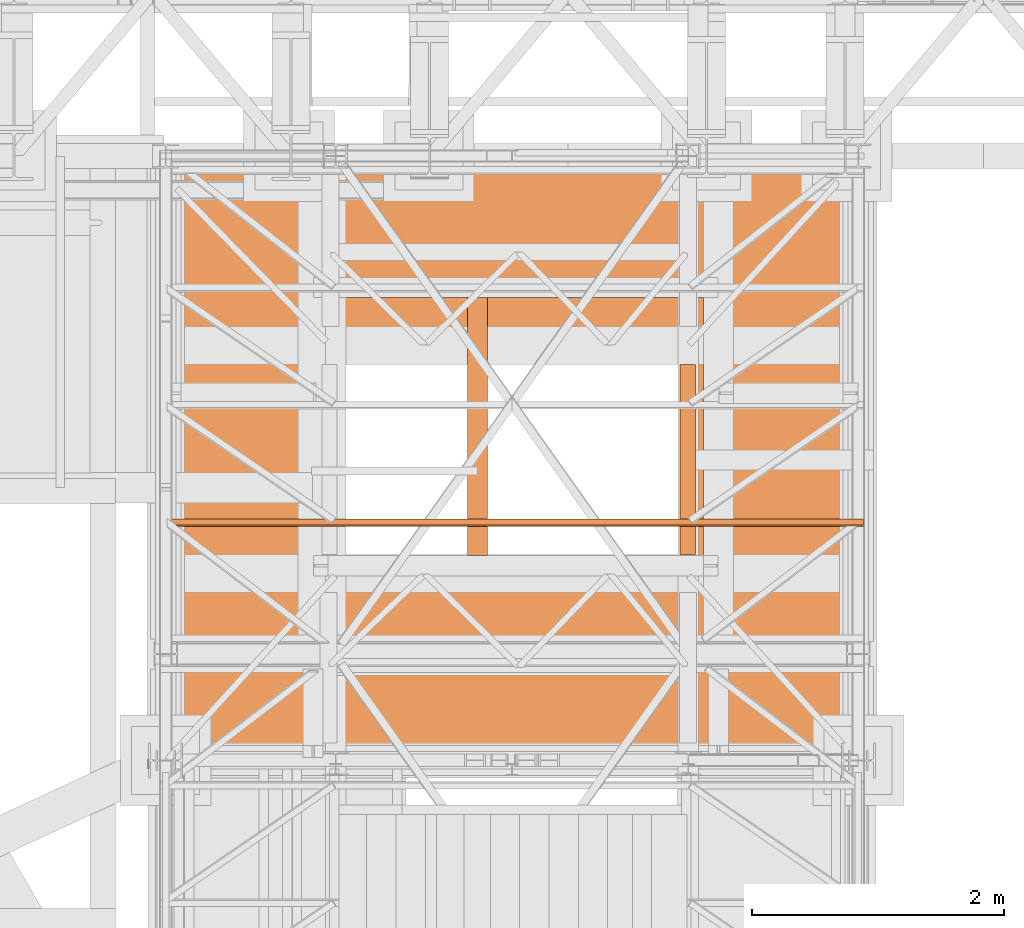
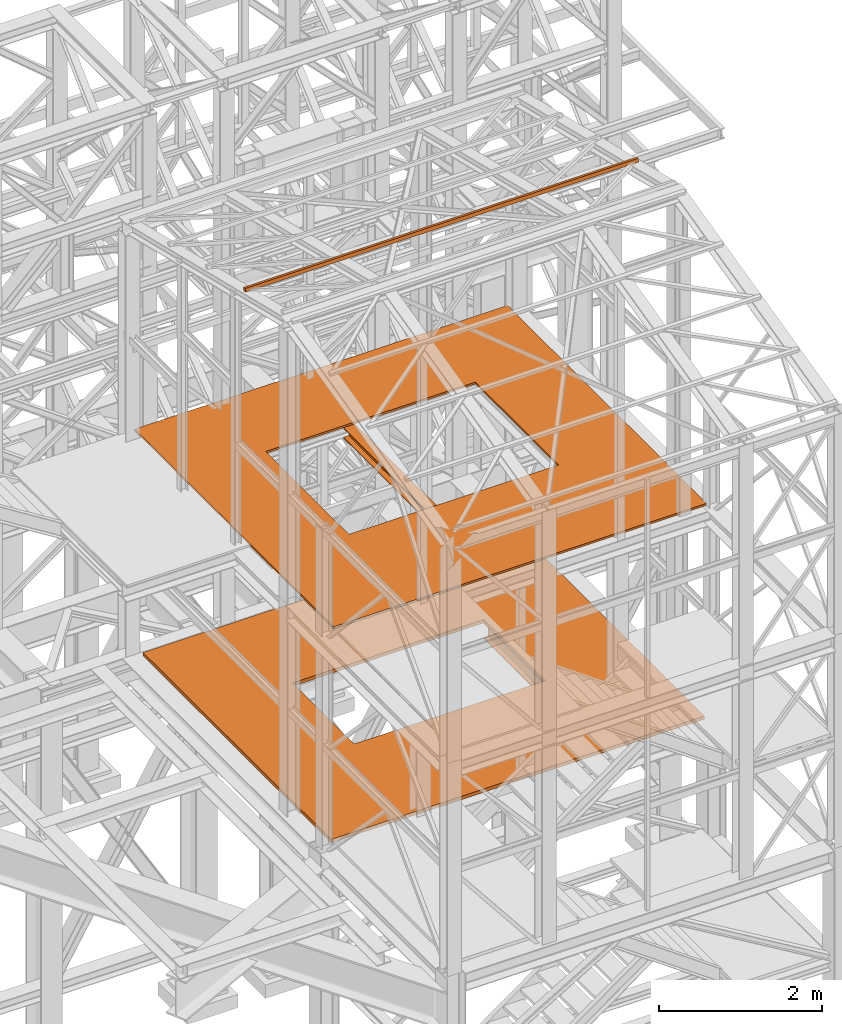
# One storey, part 64 of 208: 5 proxies.
"""IFC2X3 building model written with IfcOpenShell, lengths in millimetres."""

import ifcopenshell
import ifcopenshell.guid

model = None  # the IFC model being written
_history = None  # IfcOwnerHistory: only IFC2X3 demands one
_inside = {}  # id of a spatial element -> (the spatial element, [elements in it])
_under = {}  # id of a project, library or spatial element -> (it, [spatial elements below it])
_declared = {}  # id of a project -> (the project, [libraries it declares])
_typed = {}  # id of a type object -> (the type object, [elements of that type])
_made_of = {}  # id of a material, layer set ... -> (it, [elements and type objects made of it])


def new_model(schema):
    """Start an empty IFC model of exactly this schema.

    Asked for "IFC4X3", IfcOpenShell would pick the latest addendum, in which some entities
    have other attributes; the version numbers below select the first issue.
    IFC2X3 requires an IfcOwnerHistory on every rooted entity: one is made here for all.
    """
    global model, _history
    if schema == "IFC4X3":
        model = ifcopenshell.file(schema_version=(4, 3, 0, 0))
    else:
        model = ifcopenshell.file(schema=schema)
    _inside.clear()
    _under.clear()
    _declared.clear()
    _typed.clear()
    _made_of.clear()
    _history = None
    if model.schema == "IFC2X3":
        org = make("IfcOrganization", Name="unknown")
        user = make(
            "IfcPersonAndOrganization",
            ThePerson=make("IfcPerson", FamilyName="unknown"),
            TheOrganization=org,
        )
        app = make(
            "IfcApplication",
            ApplicationDeveloper=org,
            Version="unknown",
            ApplicationFullName="unknown",
            ApplicationIdentifier="unknown",
        )
        _history = make(
            "IfcOwnerHistory",
            OwningUser=user,
            OwningApplication=app,
            ChangeAction="ADDED",
            CreationDate=0,
        )
    return model


def make(cls, **values):
    """One entity of the class cls with the attributes given. An attribute that is None is left unset."""
    return model.create_entity(
        cls, **{name: value for name, value in values.items() if value is not None}
    )


def entity(cls, *values):
    """Any entity or typed value of the class cls, its attributes in the order of the schema. None: left unset."""
    e = model.create_entity(cls)
    for i, value in enumerate(values):
        if value is not None:
            e[i] = value
    return e


def rooted(cls, **values):
    """An entity with a GlobalId (a new one), such as an element, a storey or a relation."""
    return make(cls, GlobalId=ifcopenshell.guid.new(), OwnerHistory=_history, **values)


def si_unit(unit_type, name, prefix=None):
    """IfcSIUnit, for example si_unit("LENGTHUNIT", "METRE", prefix="MILLI")."""
    return make("IfcSIUnit", UnitType=unit_type, Prefix=prefix, Name=name)


def converted_unit(unit_type, name, factor, base, dimensions=None, offset=None):
    """IfcConversionBasedUnit, such as the inch: factor (a typed value) times the base unit."""
    return make(
        "IfcConversionBasedUnit"
        if offset is None
        else "IfcConversionBasedUnitWithOffset",
        ConversionOffset=offset,
        Dimensions=None
        if dimensions is None
        else entity("IfcDimensionalExponents", *dimensions),
        UnitType=unit_type,
        Name=name,
        ConversionFactor=make(
            "IfcMeasureWithUnit", ValueComponent=factor, UnitComponent=base
        ),
    )


def assignment(units):
    """IfcUnitAssignment: the units of a project."""
    return None if units is None else make("IfcUnitAssignment", Units=units)


def point(xyz):
    """IfcCartesianPoint."""
    return None if xyz is None else make("IfcCartesianPoint", Coordinates=xyz)


def direction(xyz):
    """IfcDirection."""
    return None if xyz is None else make("IfcDirection", DirectionRatios=xyz)


def frame(location, z_axis=None, x_axis=None):
    """IfcAxis2Placement3D, a coordinate frame: its origin and axes. An axis left out is left unset."""
    return make(
        "IfcAxis2Placement3D",
        Location=point(location),
        Axis=direction(z_axis),
        RefDirection=direction(x_axis),
    )


def origin():
    """The frame at (0, 0, 0) with its axes left unset."""
    return frame((0.0, 0.0, 0.0))


def origin_with_axes():
    """The frame at (0, 0, 0) with the z axis (0, 0, 1) and the x axis (1, 0, 0) written out."""
    return frame((0.0, 0.0, 0.0), z_axis=(0.0, 0.0, 1.0), x_axis=(1.0, 0.0, 0.0))


def place(relative_to, where):
    """IfcLocalPlacement: puts the frame where relative to a parent placement (None: the world)."""
    return make(
        "IfcLocalPlacement", PlacementRelTo=relative_to, RelativePlacement=where
    )


def context(
    kind, dimensions, precision=None, world=None, true_north=None, identifier=None
):
    """IfcGeometricRepresentationContext, for example the 3D "Model" context."""
    return make(
        "IfcGeometricRepresentationContext",
        ContextIdentifier=identifier,
        ContextType=kind,
        CoordinateSpaceDimension=dimensions,
        Precision=precision,
        WorldCoordinateSystem=world,
        TrueNorth=true_north,
    )


def subcontext(parent, identifier, kind, view, scale=None):
    """IfcGeometricRepresentationSubContext, for example "Body" below "Model"."""
    return make(
        "IfcGeometricRepresentationSubContext",
        ContextIdentifier=identifier,
        ContextType=kind,
        ParentContext=parent,
        TargetScale=scale,
        TargetView=view,
    )


def project(units=None, contexts=None):
    """IfcProject with its units and contexts."""
    return rooted(
        "IfcProject",
        Name="project",
        RepresentationContexts=contexts,
        UnitsInContext=assignment(units),
    )


def spatial(cls, under=None, at=None, **own):
    """A site, building, storey or space (cls), placed at a placement, below another one or the project."""
    s = rooted(cls, ObjectPlacement=at, **own)
    if under is not None:
        _under.setdefault(under.id(), (under, []))[1].append(s)
    return s


def faces_of(points, faces, orient=None, outer=None):
    """IfcFace entities. A face is a list of loops; a loop is a list of indices into points, from 0.

    orient and outer hold one flag for each loop. By default every Orientation is true, the
    first loop of a face is its IfcFaceOuterBound and the others are IfcFaceBound.
    """
    made = []
    for i, loops in enumerate(faces):
        bounds = []
        for j, loop in enumerate(loops):
            is_outer = j == 0 if outer is None else outer[i][j]
            bounds.append(
                make(
                    "IfcFaceOuterBound" if is_outer else "IfcFaceBound",
                    Bound=make("IfcPolyLoop", Polygon=[points[k] for k in loop]),
                    Orientation=True if orient is None else orient[i][j],
                )
            )
        made.append(make("IfcFace", Bounds=bounds))
    return made


def faceted_brep(points, faces, orient=None, outer=None, voids=None):
    """IfcFacetedBrep: a solid bounded by flat faces; with voids (closed shells), ...WithVoids."""
    shared = [point(p) for p in points]
    hull = make("IfcClosedShell", CfsFaces=faces_of(shared, faces, orient, outer))
    if voids is None:
        return make("IfcFacetedBrep", Outer=hull)
    return make(
        "IfcFacetedBrepWithVoids",
        Outer=hull,
        Voids=[
            make(cls, CfsFaces=faces_of(shared, fs, o, b)) for cls, fs, o, b in voids
        ],
    )


def shape(context_of_items, identifier, shape_type, items):
    """IfcShapeRepresentation: the items that make up one representation, for example the "Body"."""
    return make(
        "IfcShapeRepresentation",
        ContextOfItems=context_of_items,
        RepresentationIdentifier=identifier,
        RepresentationType=shape_type,
        Items=items,
    )


def made_of(thing, what):
    """Note that an element or type object is made of a material, layer set ...; save() writes the relation."""
    if what is not None:
        _made_of.setdefault(what.id(), (what, []))[1].append(thing)
    return thing


def element(
    cls,
    number,
    at=None,
    inside=None,
    cuts=None,
    type_object=None,
    material=None,
    context=None,
    identifier="Body",
    shape_type=None,
    held_by="IfcProductDefinitionShape",
    body=None,
    shapes=None,
    **own,
):
    """One element of the class cls, such as IfcWall. Its Tag is "e" and its number.

    at: its placement. inside: the storey or other place that contains it. cuts: it is an
    opening in that element (IfcRelVoidsElement). A single representation is given by context,
    identifier, shape_type and body (its items); several are given by shapes. held_by: the class
    of the entity that holds the representations. save() writes the other relations.
    """
    e = rooted(cls, Tag="e%d" % number, ObjectPlacement=at, **own)
    if body is not None:
        shapes = [shape(context, identifier, shape_type, body)]
    if shapes is not None:
        e.Representation = make(held_by, Representations=shapes)
    if inside is not None:
        _inside.setdefault(inside.id(), (inside, []))[1].append(e)
    if cuts is not None:
        rooted(
            "IfcRelVoidsElement", RelatingBuildingElement=cuts, RelatedOpeningElement=e
        )
    if type_object is not None:
        _typed.setdefault(type_object.id(), (type_object, []))[1].append(e)
    return made_of(e, material)


def aggregate(whole, parts):
    """IfcRelAggregates: a whole, such as a stair, and the parts it consists of."""
    return rooted("IfcRelAggregates", RelatingObject=whole, RelatedObjects=parts)


def save(model, path):
    """Write the relations noted so far, then the file.

    IfcRelAggregates (storeys below a building ...), IfcRelContainedInSpatialStructure (elements
    in a storey), IfcRelDefinesByType, IfcRelAssociatesMaterial and IfcRelDeclares: one each for
    every whole, place, type object, material and project.
    """
    for whole, parts in _under.values():
        aggregate(whole, parts)
    for where, things in _inside.values():
        rooted(
            "IfcRelContainedInSpatialStructure",
            RelatedElements=things,
            RelatingStructure=where,
        )
    for kind, things in _typed.values():
        rooted("IfcRelDefinesByType", RelatedObjects=things, RelatingType=kind)
    for what, things in _made_of.values():
        rooted("IfcRelAssociatesMaterial", RelatedObjects=things, RelatingMaterial=what)
    for by, libraries in _declared.values():
        rooted("IfcRelDeclares", RelatingContext=by, RelatedDefinitions=libraries)
    model.write(path)


model = new_model("IFC2X3")

# Units and contexts
model_context = context("Model", 3, precision=1e-05, world=origin())
plan_context = context("Plan", 3, precision=1e-05, world=origin())
body_context = subcontext(model_context, "Body", "Model", "MODEL_VIEW")
ifc_project = project(units=[si_unit("LENGTHUNIT", "METRE", prefix="MILLI"), converted_unit("PLANEANGLEUNIT", "DEGREE", entity("IfcPlaneAngleMeasure", 0.0174532925199433), si_unit("PLANEANGLEUNIT", "RADIAN"), dimensions=[0, 0, 0, 0, 0, 0, 0]), si_unit("AREAUNIT", "SQUARE_METRE"), si_unit("VOLUMEUNIT", "CUBIC_METRE")], contexts=[model_context, plan_context])

# Building, storey
building_placement = place(None, origin())
building = spatial("IfcBuilding", under=ifc_project, at=building_placement, CompositionType="COMPLEX")
storey_placement = place(building_placement, origin_with_axes())
storey = spatial("IfcBuildingStorey", under=building, at=storey_placement, Name="Geschoss", CompositionType="ELEMENT")

# Proxies
proxy_1_placement = place(storey_placement, frame((1298.254970018781, -22062.57439031789, 5284.990005364416), z_axis=(0.0, 0.0, 1.0), x_axis=(1.0, 0.0, 0.0)))
element("IfcBuildingElementProxy", 1, at=proxy_1_placement, inside=storey, context=body_context, shape_type="Brep", body=[
    faceted_brep([(0.01000000000021828, 0.01000000000203727, 0.01000000000021828), (5300.00999701977, 0.01000000000203727, 0.01000000000021828), (5300.009997019771, 4630.009995002234, 0.01000000000021828), (0.01000000000112777, 4630.009995002234, 0.01000000000021828), (3986.009998319893, 1634.010000189992, 0.01000000000021828), (1267.509998319894, 1634.010000189996, 0.01000000000021828), (1267.509998319895, 3144.010000189996, 0.01000000000021828), (3986.009998319894, 3144.010000189992, 0.01000000000021828), (5300.00999701977, 0.01000000000203727, 50.01000000000022), (0.01000000000021828, 0.01000000000203727, 50.01000000000022), (0.01000000000112777, 4630.009995002234, 50.01000000000022), (5300.009997019771, 4630.009995002234, 50.01000000000022), (1267.509998319894, 1634.010000189996, 50.01000000000022), (3986.009998319893, 1634.010000189992, 50.01000000000022), (3986.009998319894, 3144.010000189996, 50.01000000000022), (1267.509998319895, 3144.010000189996, 50.01000000000022), (5300.00999701977, 0.01000000000203727, 0.01000000000021828), (0.01000000000021828, 0.01000000000203727, 0.01000000000021828), (0.01000000000021828, 0.01000000000203727, 50.01000000000022), (5300.00999701977, 0.01000000000203727, 50.01000000000022), (5300.009997019771, 4630.009995002234, 0.01000000000021828), (5300.00999701977, 0.01000000000203727, 0.01000000000021828), (5300.00999701977, 0.01000000000203727, 50.01000000000022), (5300.009997019771, 4630.009995002234, 50.01000000000022), (0.01000000000112777, 4630.009995002234, 0.01000000000021828), (5300.009997019771, 4630.009995002234, 0.01000000000021828), (5300.009997019771, 4630.009995002234, 50.01000000000022), (0.01000000000112777, 4630.009995002234, 50.01000000000022), (0.01000000000021828, 0.01000000000203727, 0.01000000000021828), (0.01000000000112777, 4630.009995002234, 0.01000000000021828), (0.01000000000112777, 4630.009995002234, 50.01000000000022), (0.01000000000021828, 0.01000000000203727, 50.01000000000022), (1267.509998319894, 1634.010000189996, 0.01000000000021828), (3986.009998319893, 1634.010000189992, 0.01000000000021828), (3986.009998319893, 1634.010000189992, 50.01000000000022), (1267.509998319894, 1634.010000189996, 50.01000000000022), (3986.009998319893, 1634.010000189992, 0.01000000000021828), (3986.009998319894, 3144.010000189992, 0.01000000000021828), (3986.009998319894, 3144.010000189996, 50.01000000000022), (3986.009998319893, 1634.010000189992, 50.01000000000022), (3986.009998319894, 3144.010000189992, 0.01000000000021828), (1267.509998319895, 3144.010000189996, 0.01000000000021828), (1267.509998319895, 3144.010000189996, 50.01000000000022), (3986.009998319894, 3144.010000189996, 50.01000000000022), (1267.509998319895, 3144.010000189996, 0.01000000000021828), (1267.509998319894, 1634.010000189996, 0.01000000000021828), (1267.509998319894, 1634.010000189996, 50.01000000000022), (1267.509998319895, 3144.010000189996, 50.01000000000022)], [[[0, 1, 2, 3], [4, 5, 6, 7]], [[8, 9, 10, 11], [12, 13, 14, 15]], [[16, 17, 18, 19]], [[20, 21, 22, 23]], [[24, 25, 26, 27]], [[28, 29, 30, 31]], [[32, 33, 34, 35]], [[36, 37, 38, 39]], [[40, 41, 42, 43]], [[44, 45, 46, 47]]], orient=[[False, False], [False, False], [False], [False], [False], [False], [False], [False], [False], [False]]),
])
proxy_2_placement = place(storey_placement, frame((3592.968166618113, -20436.85029743702, 8332.990002086155), z_axis=(0.0, 0.0, 1.0), x_axis=(1.0, 0.0, 0.0)))
element("IfcBuildingElementProxy", 2, at=proxy_2_placement, inside=storey, context=body_context, shape_type="Brep", body=[
    faceted_brep([(160.0100000000002, 2050.009999999998, 0.01000000000021828), (160.0100000000002, 0.00999999999839929, 0.01000000000021828), (160.0100000000002, 0.00999999999839929, 9.010000000000218), (160.0100000000002, 2050.009999999998, 9.010000000000218), (160.0100000000002, 2050.009999999998, 9.010000000000218), (160.0100000000002, 0.00999999999839929, 9.010000000000218), (83.01000000000022, 0.00999999999839929, 9.010000000000218), (83.01000000000022, 2050.009999999998, 9.010000000000218), (83.01000000000022, 2050.009999999998, 9.010000000000218), (83.01000000000022, 0.00999999999839929, 9.010000000000218), (83.01000000000022, 0.00999999999839929, 143.0100000000002), (83.01000000000022, 2050.009999999998, 143.0100000000002), (83.01000000000022, 2050.009999999998, 143.0100000000002), (83.01000000000022, 0.00999999999839929, 143.0100000000002), (160.0100000000002, 0.00999999999839929, 143.0100000000002), (160.0100000000002, 2050.009999999998, 143.0100000000002), (160.0100000000002, 2050.009999999998, 143.0100000000002), (160.0100000000002, 0.00999999999839929, 143.0100000000002), (160.0100000000002, 0.00999999999839929, 152.0100000000002), (160.0100000000002, 2050.009999999998, 152.0100000000002), (160.0100000000002, 2050.009999999998, 152.0100000000002), (160.0100000000002, 0.00999999999839929, 152.0100000000002), (0.01000000000021828, 0.00999999999839929, 152.0100000000002), (0.01000000000021828, 2050.009999999998, 152.0100000000002), (0.01000000000021828, 2050.009999999998, 152.0100000000002), (0.01000000000021828, 0.00999999999839929, 152.0100000000002), (0.01000000000021828, 0.00999999999839929, 143.0100000000002), (0.01000000000021828, 2050.009999999998, 143.0100000000002), (0.01000000000021828, 2050.009999999998, 143.0100000000002), (0.01000000000021828, 0.00999999999839929, 143.0100000000002), (77.01000000000022, 0.00999999999839929, 143.0100000000002), (77.01000000000022, 2050.009999999998, 143.0100000000002), (77.01000000000022, 2050.009999999998, 143.0100000000002), (77.01000000000022, 0.00999999999839929, 143.0100000000002), (77.01000000000022, 0.00999999999839929, 9.010000000000218), (77.01000000000022, 2050.009999999998, 9.010000000000218), (77.01000000000022, 2050.009999999998, 9.010000000000218), (77.01000000000022, 0.00999999999839929, 9.010000000000218), (0.01000000000021828, 0.00999999999839929, 9.010000000000218), (0.01000000000021828, 2050.009999999998, 9.010000000000218), (0.01000000000021828, 2050.009999999998, 9.010000000000218), (0.01000000000021828, 0.00999999999839929, 9.010000000000218), (0.01000000000021828, 0.00999999999839929, 0.01000000000021828), (0.01000000000021828, 2050.009999999998, 0.01000000000021828), (0.01000000000021828, 2050.009999999998, 0.01000000000021828), (0.01000000000021828, 0.00999999999839929, 0.01000000000021828), (160.0100000000002, 0.00999999999839929, 0.01000000000021828), (160.0100000000002, 2050.009999999998, 0.01000000000021828), (160.0100000000002, 2050.009999999998, 0.01000000000021828), (160.0100000000002, 2050.009999999998, 9.010000000000218), (83.01000000000022, 2050.009999999998, 9.010000000000218), (83.01000000000022, 2050.009999999998, 143.0100000000002), (160.0100000000002, 2050.009999999998, 143.0100000000002), (160.0100000000002, 2050.009999999998, 152.0100000000002), (0.01000000000021828, 2050.009999999998, 152.0100000000002), (0.01000000000021828, 2050.009999999998, 143.0100000000002), (77.01000000000022, 2050.009999999998, 143.0100000000002), (77.01000000000022, 2050.009999999998, 9.010000000000218), (0.01000000000021828, 2050.009999999998, 9.010000000000218), (0.01000000000021828, 2050.009999999998, 0.01000000000021828), (160.0100000000002, 0.00999999999839929, 0.01000000000021828), (0.01000000000021828, 0.00999999999839929, 0.01000000000021828), (0.01000000000021828, 0.00999999999839929, 9.010000000000218), (77.01000000000022, 0.00999999999839929, 9.010000000000218), (77.01000000000022, 0.00999999999839929, 143.0100000000002), (0.01000000000021828, 0.00999999999839929, 143.0100000000002), (0.01000000000021828, 0.00999999999839929, 152.0100000000002), (160.0100000000002, 0.00999999999839929, 152.0100000000002), (160.0100000000002, 0.00999999999839929, 143.0100000000002), (83.01000000000022, 0.00999999999839929, 143.0100000000002), (83.01000000000022, 0.00999999999839929, 9.010000000000218), (160.0100000000002, 0.00999999999839929, 9.010000000000218)], [[[0, 1, 2, 3]], [[4, 5, 6, 7]], [[8, 9, 10, 11]], [[12, 13, 14, 15]], [[16, 17, 18, 19]], [[20, 21, 22, 23]], [[24, 25, 26, 27]], [[28, 29, 30, 31]], [[32, 33, 34, 35]], [[36, 37, 38, 39]], [[40, 41, 42, 43]], [[44, 45, 46, 47]], [[48, 49, 50, 51, 52, 53, 54, 55, 56, 57, 58, 59]], [[60, 61, 62, 63, 64, 65, 66, 67, 68, 69, 70, 71]]], orient=[[False], [False], [False], [False], [False], [False], [False], [False], [False], [False], [False], [False], [False], [False]]),
])
proxy_3_placement = place(storey_placement, frame((1333.25497001878, -22062.57439031789, 8484.990002086157), z_axis=(0.0, 0.0, 1.0), x_axis=(1.0, 0.0, 0.0)))
element("IfcBuildingElementProxy", 3, at=proxy_3_placement, inside=storey, context=body_context, shape_type="Brep", body=[
    faceted_brep([(0.01000000000021828, 0.00999999999839929, 0.01000000000021828), (5300.009997019771, 0.00999999999839929, 0.01000000000021828), (5300.009997019771, 4900.010004949752, 0.01000000000021828), (0.01000000000112777, 4900.010004949756, 0.01000000000021828), (4135.009993741514, 1625.734092880863, 0.01000000000021828), (1155.010003278258, 1625.734092880866, 0.01000000000021828), (1155.010003278258, 3675.734081555984, 0.01000000000021828), (4135.009993741515, 3675.734081555984, 0.01000000000021828), (5300.009997019771, 0.00999999999839929, 30.01000000000022), (0.01000000000021828, 0.00999999999839929, 30.01000000000022), (0.01000000000112777, 4900.010004949756, 30.01000000000022), (5300.009997019771, 4900.010004949752, 30.01000000000022), (1155.010003278258, 1625.734092880866, 30.01000000000022), (4135.009993741513, 1625.734092880863, 30.01000000000022), (4135.009993741514, 3675.734081555984, 30.01000000000022), (1155.010003278258, 3675.734081555984, 30.01000000000022), (5300.009997019771, 0.00999999999839929, 0.01000000000021828), (0.01000000000021828, 0.00999999999839929, 0.01000000000021828), (0.01000000000021828, 0.00999999999839929, 30.01000000000022), (5300.009997019771, 0.00999999999839929, 30.01000000000022), (5300.009997019771, 4900.010004949752, 0.01000000000021828), (5300.009997019771, 0.00999999999839929, 0.01000000000021828), (5300.009997019771, 0.00999999999839929, 30.01000000000022), (5300.009997019771, 4900.010004949752, 30.01000000000022), (0.01000000000112777, 4900.010004949756, 0.01000000000021828), (5300.009997019771, 4900.010004949752, 0.01000000000021828), (5300.009997019771, 4900.010004949752, 30.01000000000022), (0.01000000000112777, 4900.010004949756, 30.01000000000022), (0.01000000000021828, 0.00999999999839929, 0.01000000000021828), (0.01000000000112777, 4900.010004949756, 0.01000000000021828), (0.01000000000112777, 4900.010004949756, 30.01000000000022), (0.01000000000021828, 0.00999999999839929, 30.01000000000022), (1155.010003278258, 1625.734092880866, 0.01000000000021828), (4135.009993741514, 1625.734092880863, 0.01000000000021828), (4135.009993741513, 1625.734092880863, 30.01000000000022), (1155.010003278258, 1625.734092880866, 30.01000000000022), (4135.009993741514, 1625.734092880863, 0.01000000000021828), (4135.009993741515, 3675.734081555984, 0.01000000000021828), (4135.009993741514, 3675.734081555984, 30.01000000000022), (4135.009993741513, 1625.734092880863, 30.01000000000022), (4135.009993741515, 3675.734081555984, 0.01000000000021828), (1155.010003278258, 3675.734081555984, 0.01000000000021828), (1155.010003278258, 3675.734081555984, 30.01000000000022), (4135.009993741514, 3675.734081555984, 30.01000000000022), (1155.010003278258, 3675.734081555984, 0.01000000000021828), (1155.010003278258, 1625.734092880866, 0.01000000000021828), (1155.010003278258, 1625.734092880866, 30.01000000000022), (1155.010003278258, 3675.734081555984, 30.01000000000022)], [[[0, 1, 2, 3], [4, 5, 6, 7]], [[8, 9, 10, 11], [12, 13, 14, 15]], [[16, 17, 18, 19]], [[20, 21, 22, 23]], [[24, 25, 26, 27]], [[28, 29, 30, 31]], [[32, 33, 34, 35]], [[36, 37, 38, 39]], [[40, 41, 42, 43]], [[44, 45, 46, 47]]], orient=[[False, False], [False, False], [False], [False], [False], [False], [False], [False], [False], [False]]),
])
proxy_4_placement = place(storey_placement, frame((1157.254971121463, -20206.02192199566, 12464.98408158565), z_axis=(0.0, 0.0, 1.0), x_axis=(1.0, 0.0, 0.0)))
element("IfcBuildingElementProxy", 4, at=proxy_4_placement, inside=storey, context=body_context, shape_type="Brep", body=[
    faceted_brep([(5582.010002264973, 11.80406569683692, 60.39315927079588), (5582.010002264973, 60.39315927079224, 48.59909357395736), (5582.010002264973, 48.59909357395372, 0.01000000000021828), (5582.010002264973, 0.00999999999839929, 11.80406569683873), (0.01000000000021828, 60.39315927079224, 48.59909357395736), (0.01000000000021828, 11.80406569683692, 60.39315927079588), (0.01000000000021828, 0.00999999999839929, 11.80406569683873), (0.01000000000021828, 48.59909357395372, 0.01000000000021828), (5582.010002264973, 60.39315927079224, 48.59909357395736), (5582.010002264973, 11.80406569683692, 60.39315927079588), (0.01000000000021828, 11.80406569683692, 60.39315927079588), (0.01000000000021828, 60.39315927079224, 48.59909357395736), (5582.010002264973, 48.59909357395372, 0.01000000000021828), (5582.010002264973, 60.39315927079224, 48.59909357395736), (0.01000000000021828, 60.39315927079224, 48.59909357395736), (0.01000000000021828, 48.59909357395372, 0.01000000000021828), (5582.010002264973, 0.00999999999839929, 11.80406569683873), (5582.010002264973, 48.59909357395372, 0.01000000000021828), (0.01000000000021828, 48.59909357395372, 0.01000000000021828), (0.01000000000021828, 0.00999999999839929, 11.80406569683873), (5582.010002264973, 11.80406569683692, 60.39315927079588), (5582.010002264973, 0.00999999999839929, 11.80406569683873), (0.01000000000021828, 0.00999999999839929, 11.80406569683873), (0.01000000000021828, 11.80406569683692, 60.39315927079588)], [[[0, 1, 2, 3]], [[4, 5, 6, 7]], [[8, 9, 10, 11]], [[12, 13, 14, 15]], [[16, 17, 18, 19]], [[20, 21, 22, 23]]], orient=[[False], [False], [False], [False], [False], [False]]),
])
proxy_5_placement = place(storey_placement, frame((5284.254968338673, -20428.5743901279, 5044.990005364415), z_axis=(0.0, 0.0, 1.0), x_axis=(1.0, 0.0, 0.0)))
element("IfcBuildingElementProxy", 5, at=proxy_5_placement, inside=storey, context=body_context, shape_type="Brep", body=[
    faceted_brep([(120.0100000000002, 1510.010000000006, 0.01000000000021828), (120.0100000000002, 0.01000000000567525, 0.01000000000021828), (120.0100000000002, 0.01000000000567525, 9.810000190735082), (120.0100000000002, 1510.010000000006, 9.810000190735082), (120.0100000000002, 1510.010000000006, 9.810000190735082), (120.0100000000002, 0.01000000000567525, 9.810000190735082), (78.10999990463279, 0.01000000000203727, 9.810000190735082), (78.10999990463279, 1510.010000000006, 9.810000190735082), (78.10999990463279, 1510.010000000006, 9.810000190735082), (78.10999990463279, 0.01000000000203727, 9.810000190735082), (74.22772724864444, 0.01000000000567525, 10.32115675323166), (74.22772724864444, 1510.010000000006, 10.32115675323075), (74.22772724864444, 1510.010000000006, 10.32115675323075), (74.22772724864444, 0.01000000000567525, 10.32115675323166), (70.61002177988667, 0.01000000000567525, 11.81965942306215), (70.61002177988667, 1510.010000000006, 11.81965942306215), (70.61002177988667, 1510.010000000006, 11.81965942306215), (70.61002177988667, 0.01000000000567525, 11.81965942306215), (67.5033981868346, 0.01000000000567525, 14.2033984729369), (67.5033981868346, 1510.010000000006, 14.2033984729369), (67.5033981868346, 1510.010000000006, 14.2033984729369), (67.5033981868346, 0.01000000000567525, 14.2033984729369), (65.11965913696076, 0.01000000000567525, 17.31002206598896), (65.11965913696076, 1510.010000000006, 17.31002206598896), (65.11965913696076, 1510.010000000006, 17.31002206598896), (65.11965913696076, 0.01000000000567525, 17.31002206598896), (63.62115646713028, 0.01000000000567525, 20.92772753474765), (63.62115646713028, 1510.010000000006, 20.92772753474765), (63.62115646713028, 1510.010000000006, 20.92772753474765), (63.62115646713028, 0.01000000000567525, 20.92772753474765), (63.10999990463279, 0.01000000000203727, 24.81000019073508), (63.10999990463279, 1510.010000000006, 24.81000019073508), (63.10999990463279, 1510.010000000006, 24.81000019073508), (63.10999990463279, 0.01000000000203727, 24.81000019073508), (63.10999990463279, 0.01000000000567525, 215.2099998092654), (63.10999990463279, 1510.010000000006, 215.2099998092654), (63.10999990463279, 1510.010000000006, 215.2099998092654), (63.10999990463279, 0.01000000000567525, 215.2099998092654), (63.62115646713028, 0.01000000000567525, 219.0922724652519), (63.62115646713028, 1510.010000000006, 219.0922724652519), (63.62115646713028, 1510.010000000006, 219.0922724652519), (63.62115646713028, 0.01000000000567525, 219.0922724652519), (65.11965913696076, 0.01000000000567525, 222.7099779340106), (65.11965913696076, 1510.010000000006, 222.7099779340106), (65.11965913696076, 1510.010000000006, 222.7099779340106), (65.11965913696076, 0.01000000000567525, 222.7099779340106), (67.5033981868346, 0.01000000000567525, 225.8166015270635), (67.5033981868346, 1510.010000000006, 225.8166015270635), (67.5033981868346, 1510.010000000006, 225.8166015270635), (67.5033981868346, 0.01000000000567525, 225.8166015270635), (70.61002177988667, 0.01000000000203727, 228.2003405769374), (70.61002177988667, 1510.010000000006, 228.2003405769374), (70.61002177988667, 1510.010000000006, 228.2003405769374), (70.61002177988667, 0.01000000000203727, 228.2003405769374), (74.22772724864444, 0.01000000000567525, 229.6988432467679), (74.22772724864444, 1510.010000000006, 229.6988432467679), (74.22772724864444, 1510.010000000006, 229.6988432467679), (74.22772724864444, 0.01000000000567525, 229.6988432467679), (78.10999990463279, 0.01000000000567525, 230.2099998092654), (78.10999990463279, 1510.010000000006, 230.2099998092654), (78.10999990463279, 1510.010000000006, 230.2099998092654), (78.10999990463279, 0.01000000000567525, 230.2099998092654), (120.0100000000002, 0.01000000000567525, 230.2099998092654), (120.0100000000002, 1510.010000000006, 230.2099998092654), (120.0100000000002, 1510.010000000006, 230.2099998092654), (120.0100000000002, 0.01000000000567525, 230.2099998092654), (120.0100000000002, 0.01000000000567525, 240.0100000000002), (120.0100000000002, 1510.010000000006, 240.0100000000002), (120.0100000000002, 1510.010000000006, 240.0100000000002), (120.0100000000002, 0.01000000000567525, 240.0100000000002), (0.01000000000021828, 0.01000000000567525, 240.0100000000002), (0.01000000000021828, 1510.010000000006, 240.0100000000002), (0.01000000000021828, 1510.010000000006, 240.0100000000002), (0.01000000000021828, 0.01000000000567525, 240.0100000000002), (0.01000000000021828, 0.01000000000567525, 230.2099998092654), (0.01000000000021828, 1510.010000000006, 230.2099998092654), (0.01000000000021828, 1510.010000000006, 230.2099998092654), (0.01000000000021828, 0.01000000000567525, 230.2099998092654), (41.91000009536765, 0.01000000000567525, 230.2099998092654), (41.91000009536765, 1510.010000000006, 230.2099998092654), (41.91000009536765, 1510.010000000006, 230.2099998092654), (41.91000009536765, 0.01000000000567525, 230.2099998092654), (45.792272751356, 0.01000000000567525, 229.6988432467679), (45.792272751356, 1510.010000000006, 229.6988432467679), (45.792272751356, 1510.010000000006, 229.6988432467679), (45.792272751356, 0.01000000000567525, 229.6988432467679), (49.40997822011377, 0.01000000000567525, 228.2003405769374), (49.40997822011377, 1510.010000000006, 228.2003405769374), (49.40997822011377, 1510.010000000006, 228.2003405769374), (49.40997822011377, 0.01000000000567525, 228.2003405769374), (52.51660181316584, 0.01000000000567525, 225.8166015270645), (52.51660181316584, 1510.010000000006, 225.8166015270635), (52.51660181316584, 1510.010000000006, 225.8166015270635), (52.51660181316584, 0.01000000000567525, 225.8166015270645), (54.90034086303967, 0.01000000000567525, 222.7099779340106), (54.90034086303967, 1510.010000000006, 222.7099779340106), (54.90034086303967, 1510.010000000006, 222.7099779340106), (54.90034086303967, 0.01000000000567525, 222.7099779340106), (56.39884353287016, 0.01000000000567525, 219.0922724652519), (56.39884353287016, 1510.010000000006, 219.0922724652519), (56.39884353287016, 1510.010000000006, 219.0922724652519), (56.39884353287016, 0.01000000000567525, 219.0922724652519), (56.91000009536765, 0.01000000000567525, 215.2099998092654), (56.91000009536765, 1510.010000000006, 215.2099998092654), (56.91000009536765, 1510.010000000006, 215.2099998092654), (56.91000009536765, 0.01000000000567525, 215.2099998092654), (56.91000009536765, 0.01000000000567525, 24.81000019073508), (56.91000009536765, 1510.010000000006, 24.81000019073508), (56.91000009536765, 1510.010000000006, 24.81000019073508), (56.91000009536765, 0.01000000000567525, 24.81000019073508), (56.17579672995453, 0.01000000000567525, 20.17476099858959), (56.17579672995453, 1510.010000000006, 20.17476099858959), (56.17579672995453, 1510.010000000006, 20.17476099858959), (56.17579672995453, 0.01000000000567525, 20.17476099858959), (54.0452364639259, 0.01000000000567525, 15.99323626528985), (54.0452364639259, 1510.010000000006, 15.99323626528985), (54.0452364639259, 1510.010000000006, 15.99323626528985), (54.0452364639259, 0.01000000000567525, 15.99323626528985), (50.72676402081379, 0.01000000000567525, 12.67476382217774), (50.72676402081379, 1510.010000000006, 12.67476382217774), (50.72676402081379, 1510.010000000006, 12.67476382217774), (50.72676402081379, 0.01000000000567525, 12.67476382217774), (46.54523928751405, 0.01000000000567525, 10.5442035561473), (46.54523928751405, 1510.010000000006, 10.54420355614639), (46.54523928751405, 1510.010000000006, 10.54420355614639), (46.54523928751405, 0.01000000000567525, 10.5442035561473), (41.91000009536765, 0.01000000000567525, 9.810000190735082), (41.91000009536765, 1510.010000000006, 9.810000190735082), (41.91000009536765, 1510.010000000006, 9.810000190735082), (41.91000009536765, 0.01000000000567525, 9.810000190735082), (0.01000000000021828, 0.01000000000203727, 9.810000190735082), (0.01000000000021828, 1510.010000000006, 9.810000190735082), (0.01000000000021828, 1510.010000000006, 9.810000190735082), (0.01000000000021828, 0.01000000000203727, 9.810000190735082), (0.01000000000021828, 0.01000000000567525, 0.01000000000021828), (0.01000000000021828, 1510.010000000006, 0.01000000000021828), (0.01000000000021828, 1510.010000000006, 0.01000000000021828), (0.01000000000021828, 0.01000000000567525, 0.01000000000021828), (120.0100000000002, 0.01000000000567525, 0.01000000000021828), (120.0100000000002, 1510.010000000006, 0.01000000000021828), (120.0100000000002, 0.01000000000567525, 0.01000000000021828), (0.01000000000021828, 0.01000000000567525, 0.01000000000021828), (0.01000000000021828, 0.01000000000203727, 9.810000190735082), (41.91000009536765, 0.01000000000567525, 9.810000190735082), (46.54523928751405, 0.01000000000567525, 10.5442035561473), (50.72676402081379, 0.01000000000567525, 12.67476382217774), (54.0452364639259, 0.01000000000567525, 15.99323626528985), (56.17579672995453, 0.01000000000567525, 20.17476099858959), (56.91000009536765, 0.01000000000567525, 24.81000019073508), (56.91000009536765, 0.01000000000567525, 215.2099998092654), (56.39884353287016, 0.01000000000567525, 219.0922724652519), (54.90034086303967, 0.01000000000567525, 222.7099779340106), (52.51660181316584, 0.01000000000567525, 225.8166015270645), (49.40997822011377, 0.01000000000567525, 228.2003405769374), (45.792272751356, 0.01000000000567525, 229.6988432467679), (41.91000009536765, 0.01000000000567525, 230.2099998092654), (0.01000000000021828, 0.01000000000567525, 230.2099998092654), (0.01000000000021828, 0.01000000000567525, 240.0100000000002), (120.0100000000002, 0.01000000000567525, 240.0100000000002), (120.0100000000002, 0.01000000000567525, 230.2099998092654), (78.10999990463279, 0.01000000000567525, 230.2099998092654), (74.22772724864444, 0.01000000000567525, 229.6988432467679), (70.61002177988667, 0.01000000000203727, 228.2003405769374), (67.5033981868346, 0.01000000000567525, 225.8166015270635), (65.11965913696076, 0.01000000000567525, 222.7099779340106), (63.62115646713028, 0.01000000000567525, 219.0922724652519), (63.10999990463279, 0.01000000000567525, 215.2099998092654), (63.10999990463279, 0.01000000000203727, 24.81000019073508), (63.62115646713028, 0.01000000000567525, 20.92772753474765), (65.11965913696076, 0.01000000000567525, 17.31002206598896), (67.5033981868346, 0.01000000000567525, 14.2033984729369), (70.61002177988667, 0.01000000000567525, 11.81965942306215), (74.22772724864444, 0.01000000000567525, 10.32115675323166), (78.10999990463279, 0.01000000000203727, 9.810000190735082), (120.0100000000002, 0.01000000000567525, 9.810000190735082), (120.0100000000002, 1510.010000000006, 9.810000190735082), (78.10999990463279, 1510.010000000006, 9.810000190735082), (74.22772724864444, 1510.010000000006, 10.32115675323075), (70.61002177988667, 1510.010000000006, 11.81965942306215), (67.5033981868346, 1510.010000000006, 14.2033984729369), (65.11965913696076, 1510.010000000006, 17.31002206598896), (63.62115646713028, 1510.010000000006, 20.92772753474765), (63.10999990463279, 1510.010000000006, 24.81000019073508), (63.10999990463279, 1510.010000000006, 215.2099998092654), (63.62115646713028, 1510.010000000006, 219.0922724652519), (65.11965913696076, 1510.010000000006, 222.7099779340106), (67.5033981868346, 1510.010000000006, 225.8166015270635), (70.61002177988667, 1510.010000000006, 228.2003405769374), (74.22772724864444, 1510.010000000006, 229.6988432467679), (78.10999990463279, 1510.010000000006, 230.2099998092654), (120.0100000000002, 1510.010000000006, 230.2099998092654), (120.0100000000002, 1510.010000000006, 240.0100000000002), (0.01000000000021828, 1510.010000000006, 240.0100000000002), (0.01000000000021828, 1510.010000000006, 230.2099998092654), (41.91000009536765, 1510.010000000006, 230.2099998092654), (45.792272751356, 1510.010000000006, 229.6988432467679), (49.40997822011377, 1510.010000000006, 228.2003405769374), (52.51660181316584, 1510.010000000006, 225.8166015270635), (54.90034086303967, 1510.010000000006, 222.7099779340106), (56.39884353287016, 1510.010000000006, 219.0922724652519), (56.91000009536765, 1510.010000000006, 215.2099998092654), (56.91000009536765, 1510.010000000006, 24.81000019073508), (56.17579672995453, 1510.010000000006, 20.17476099858959), (54.0452364639259, 1510.010000000006, 15.99323626528985), (50.72676402081379, 1510.010000000006, 12.67476382217774), (46.54523928751405, 1510.010000000006, 10.54420355614639), (41.91000009536765, 1510.010000000006, 9.810000190735082), (0.01000000000021828, 1510.010000000006, 9.810000190735082), (0.01000000000021828, 1510.010000000006, 0.01000000000021828), (120.0100000000002, 1510.010000000006, 0.01000000000021828)], [[[0, 1, 2, 3]], [[4, 5, 6, 7]], [[8, 9, 10, 11]], [[12, 13, 14, 15]], [[16, 17, 18, 19]], [[20, 21, 22, 23]], [[24, 25, 26, 27]], [[28, 29, 30, 31]], [[32, 33, 34, 35]], [[36, 37, 38, 39]], [[40, 41, 42, 43]], [[44, 45, 46, 47]], [[48, 49, 50, 51]], [[52, 53, 54, 55]], [[56, 57, 58, 59]], [[60, 61, 62, 63]], [[64, 65, 66, 67]], [[68, 69, 70, 71]], [[72, 73, 74, 75]], [[76, 77, 78, 79]], [[80, 81, 82, 83]], [[84, 85, 86, 87]], [[88, 89, 90, 91]], [[92, 93, 94, 95]], [[96, 97, 98, 99]], [[100, 101, 102, 103]], [[104, 105, 106, 107]], [[108, 109, 110, 111]], [[112, 113, 114, 115]], [[116, 117, 118, 119]], [[120, 121, 122, 123]], [[124, 125, 126, 127]], [[128, 129, 130, 131]], [[132, 133, 134, 135]], [[136, 137, 138, 139]], [[140, 141, 142, 143, 144, 145, 146, 147, 148, 149, 150, 151, 152, 153, 154, 155, 156, 157, 158, 159, 160, 161, 162, 163, 164, 165, 166, 167, 168, 169, 170, 171, 172, 173, 174]], [[175, 176, 177, 178, 179, 180, 181, 182, 183, 184, 185, 186, 187, 188, 189, 190, 191, 192, 193, 194, 195, 196, 197, 198, 199, 200, 201, 202, 203, 204, 205, 206, 207, 208, 209]]], orient=[[False], [False], [False], [False], [False], [False], [False], [False], [False], [False], [False], [False], [False], [False], [False], [False], [False], [False], [False], [False], [False], [False], [False], [False], [False], [False], [False], [False], [False], [False], [False], [False], [False], [False], [False], [False], [False]]),
])

save(model, "model.ifc")
